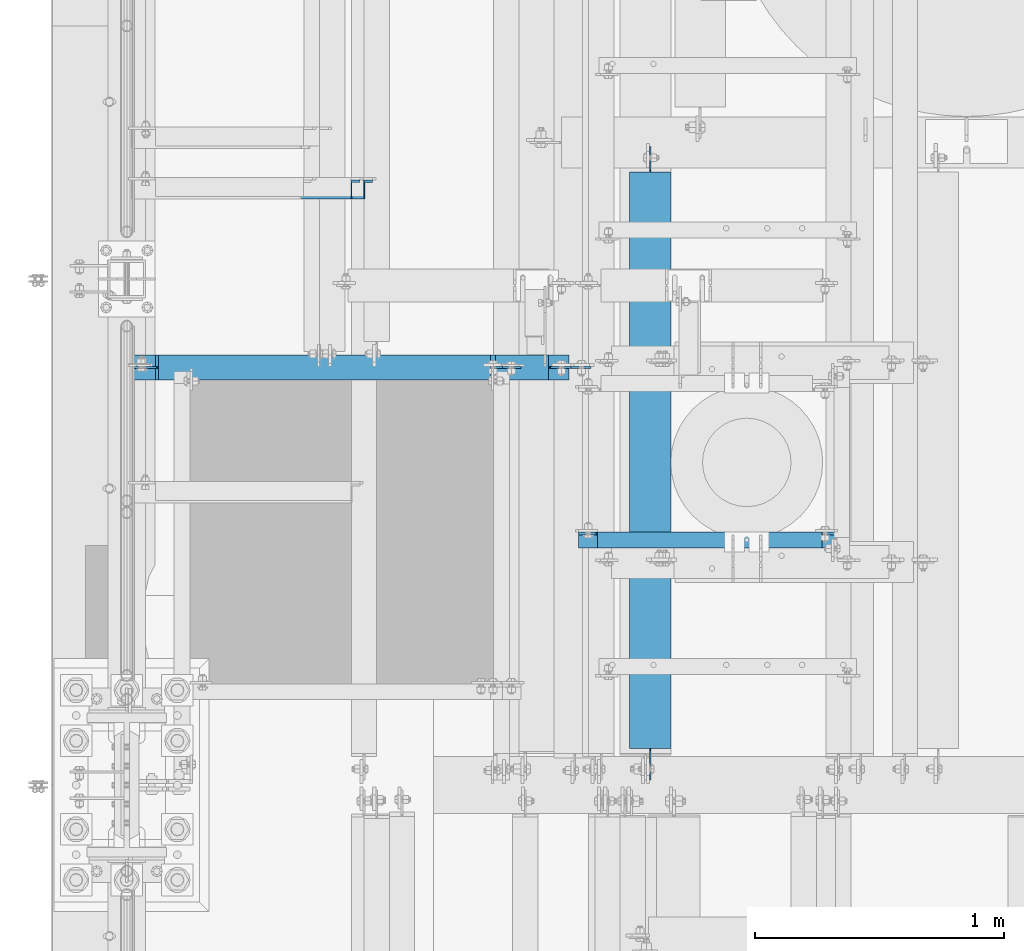
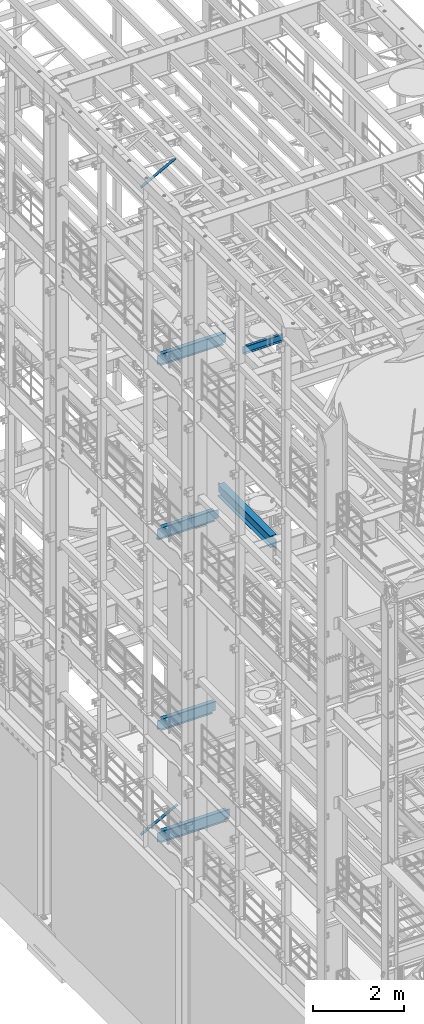
# One storey, part 1017 of 1876: 6 beams, 2 members, 8 elements without a shape of their own.
"""IFC2X3 building model written with IfcOpenShell, lengths in millimetres."""

from ifc_helpers import new_model, si_unit, frame, origin_with_axes, place, context, subcontext, project, spatial, faceted_brep, material, type_object, element, aggregate, save


model = new_model("IFC2X3")

# Units and contexts
model_context = context("Model", 3, precision=1e-05, world=origin_with_axes())
body_context = subcontext(model_context, "Body", "Model", "MODEL_VIEW")
ifc_project = project(units=[si_unit("LENGTHUNIT", "METRE", prefix="MILLI"), si_unit("AREAUNIT", "SQUARE_METRE"), si_unit("VOLUMEUNIT", "CUBIC_METRE"), si_unit("MASSUNIT", "GRAM", prefix="KILO"), si_unit("TIMEUNIT", "SECOND"), si_unit("PLANEANGLEUNIT", "RADIAN"), si_unit("SOLIDANGLEUNIT", "STERADIAN"), si_unit("THERMODYNAMICTEMPERATUREUNIT", "DEGREE_CELSIUS"), si_unit("LUMINOUSINTENSITYUNIT", "LUMEN")], contexts=[model_context])

# Site, building, storey
site_placement = place(None, origin_with_axes())
site = spatial("IfcSite", under=ifc_project, at=site_placement, CompositionType="ELEMENT")
building_placement = place(site_placement, origin_with_axes())
building = spatial("IfcBuilding", under=site, at=building_placement, Name="Undefined", CompositionType="ELEMENT")
storey_placement = place(building_placement, origin_with_axes())
storey = spatial("IfcBuildingStorey", under=building, at=storey_placement, Name="Undefined", CompositionType="ELEMENT", Elevation=0.0)

# Assembly, member
assembly_1_placement = place(storey_placement, origin_with_axes())
assembly_1 = element("IfcElementAssembly", 1, at=assembly_1_placement, inside=storey, AssemblyPlace="NOTDEFINED", PredefinedType="RIGID_FRAME")
ifc_material_1 = material(Name="STEEL/A36")
member_type = type_object("IfcMemberType", Name="L3X3X3/8", PredefinedType="NOTDEFINED")
member_1_placement = place(assembly_1_placement, frame((17.6081923269563, 3914.775, 4576.47197854001), z_axis=(0.0, -1.0, 0.0), x_axis=(0.885896503105539, 0.0, 0.463882944055263)))
member_1 = element("IfcMember", 2, at=member_1_placement, type_object=member_type, material=ifc_material_1, ObjectType="L3X3X3/8", context=body_context, shape_type="Brep", body=[
    faceted_brep([(22.4738417769599, 38.1000000000004, -38.0999999999999), (22.4738417769599, 38.1000000000004, 38.0999999999999), (1074.30197854536, 38.1000000002496, 38.0999999999999), (1074.30197854536, 38.1000000002496, -38.0999999999999), (22.4738417769613, 28.5749999999998, 38.0999999999999), (1074.30197854535, 28.5750000002463, 38.0999999999999), (22.4738417769613, 28.5749999999998, -28.5749999999998), (1074.30197854535, 28.5750000002463, -28.5749999999998), (22.4738417769699, -38.100000000004, -28.5749999999998), (1074.30197854533, -38.099999999773, -28.5749999999998), (22.4738417769699, -38.100000000004, -38.0999999999999), (1074.30197854533, -38.099999999773, -38.0999999999999)], [[[0, 1, 2, 3]], [[1, 4, 5, 2]], [[4, 6, 7, 5]], [[6, 8, 9, 7]], [[8, 10, 11, 9]], [[10, 0, 3, 11]], [[5, 7, 9, 11, 3, 2]], [[10, 8, 6, 4, 1, 0]]]),
])
aggregate(assembly_1, [member_1])

assembly_2_placement = place(storey_placement, origin_with_axes())
assembly_2 = element("IfcElementAssembly", 3, at=assembly_2_placement, inside=storey, AssemblyPlace="NOTDEFINED", PredefinedType="RIGID_FRAME")
member_2_placement = place(assembly_2_placement, frame((18.2754879686868, 3914.775, 22001.0692535961), z_axis=(0.0, -1.0, 0.0), x_axis=(0.877448093107104, 0.0, 0.479671600058526)))
member_2 = element("IfcMember", 4, at=member_2_placement, type_object=member_type, material=ifc_material_1, ObjectType="L3X3X3/8", context=body_context, shape_type="Brep", body=[
    faceted_brep([(22.6152978728696, 38.0999999999985, -38.0999999999999), (22.6152978728696, 38.0999999999985, 38.0999999999999), (1025.78606203808, 38.1000000013628, 38.0999999999999), (1025.78606203808, 38.1000000013628, -38.0999999999999), (22.6152978728605, 28.5750000000044, 38.0999999999999), (1025.78606203807, 28.5750000013722, 38.0999999999999), (22.6152978728605, 28.5750000000044, -28.5749999999998), (1025.78606203807, 28.5750000013722, -28.5749999999998), (22.6152978728023, -38.0999999999367, -28.5749999999998), (1025.78606203801, -38.0999999985652, -28.5749999999998), (22.6152978728023, -38.0999999999367, -38.0999999999999), (1025.78606203801, -38.0999999985652, -38.0999999999999)], [[[0, 1, 2, 3]], [[1, 4, 5, 2]], [[4, 6, 7, 5]], [[6, 8, 9, 7]], [[8, 10, 11, 9]], [[10, 0, 3, 11]], [[5, 7, 9, 11, 3, 2]], [[10, 8, 6, 4, 1, 0]]]),
])
aggregate(assembly_2, [member_2])

# Assembly, beam
assembly_3_placement = place(storey_placement, origin_with_axes())
assembly_3 = element("IfcElementAssembly", 5, at=assembly_3_placement, inside=storey, Name="BEAM", AssemblyPlace="NOTDEFINED", PredefinedType="RIGID_FRAME")
ifc_material_2 = material(Name="STEEL/A992")
beam_type_1 = type_object("IfcBeamType", Name="W12X16", PredefinedType="NOTDEFINED")
beam_1_placement = place(assembly_3_placement, frame((3.18323145620525e-12, 3200.4, 17830.8), z_axis=(0.0, 0.0, 1.0), x_axis=(1.0, 0.0, 0.0)))
beam_1 = element("IfcBeam", 6, at=beam_1_placement, type_object=beam_type_1, material=ifc_material_2, Name="BEAM", ObjectType="W12X16", context=body_context, shape_type="Brep", body=[
    faceted_brep([(19.84375, -3.17499999999995, -126.999999999996), (19.84375, 3.17499999999995, -126.999999999996), (96.0437501907345, 3.17500002364682, -126.999999999996), (96.0437501907345, -3.17499999999995, -126.999999999996), (100.90382970878, 3.17500002380461, -127.966729922584), (100.90382970878, -3.17499999999995, -127.966729922584), (105.024006176934, 3.17500002425209, -130.719743823061), (105.024006176934, -3.17499999999995, -130.719743823061), (107.777020077412, 3.17500002492102, -134.839920291215), (107.777020077412, -3.17499999999995, -134.839920291215), (108.74375, -3.17499999999995, -139.699999809261), (108.74375, 3.17500002570978, -139.699999809261), (108.74375, 3.17500009516311, -146.049999999999), (108.74375, 50.8, -146.049999999999), (108.74375, 50.8, -152.400000000001), (108.74375, -50.8, -152.400000000001), (108.74375, -50.8, -146.049999999999), (108.74375, -3.17499999999995, -146.049999999999), (1693.8625, 50.8000000000002, 146.049999999999), (1693.8625, 3.17500000000018, 146.049999999999), (126.20625, 3.17499999999995, 146.049999999999), (126.20625, 50.8, 146.049999999999), (113.506250190735, -3.17499999999995, 107.950000000004), (113.506250190735, 3.17499998606149, 107.950000000004), (19.84375, 3.17499999999995, 107.950000000004), (19.84375, -3.17499999999995, 107.950000000004), (118.366329708781, -3.17499999999995, 108.916729922592), (118.366329708781, 3.17499998590552, 108.916729922592), (122.486506176934, -3.17499999999995, 111.669743823069), (122.486506176934, 3.17499998546009, 111.669743823069), (125.239520077413, -3.17499999999995, 115.789920291223), (125.239520077413, 3.17499998479298, 115.789920291223), (126.20625, -3.17499999999995, 120.64999980927), (126.20625, 3.17499998400558, 120.64999980927), (1693.8625, -50.8000000000002, 152.400000000001), (1693.8625, 50.8000000000002, 152.400000000001), (126.20625, 50.8, 152.400000000001), (126.20625, -50.8, 152.400000000001), (1693.8625, -50.8000000000002, 146.049999999999), (126.20625, -50.8, 146.049999999999), (1693.8625, -3.17500000000018, 146.049999999999), (126.20625, -3.17499999999995, 146.049999999999), (1693.8625, -3.17500000000018, 139.699999809265), (1693.8625, 3.17500000000018, 139.699999809265), (1694.82922992258, -3.17500000000018, 134.839920291219), (1694.82922992258, 3.17500000000018, 134.839920291219), (1697.58224382306, -3.17500000000018, 130.719743823065), (1697.58224382306, 3.17500000000018, 130.719743823065), (1701.70242029122, -3.17500000000018, 127.966729922588), (1701.70242029122, 3.17500000000018, 127.966729922588), (1706.56249980926, -3.17500000000018, 127.0), (1706.56249980926, 3.17500000000018, 127.0), (1782.7625, -3.17500000000018, 127.0), (1782.7625, 3.17500000000018, 127.0), (1782.7625, -3.17500000000018, -127.0), (1782.7625, 3.17500000000018, -127.0), (1706.56249980926, -3.17500000000018, -127.0), (1706.56249980926, 3.17500000000018, -127.0), (1701.70242029122, -3.17500000000018, -127.966729922588), (1701.70242029122, 3.17500000000018, -127.966729922588), (1697.58224382306, -3.17500000000018, -130.719743823065), (1697.58224382306, 3.17500000000018, -130.719743823065), (1694.82922992258, -3.17500000000018, -134.839920291219), (1694.82922992258, 3.17500000000018, -134.839920291219), (1693.8625, -3.17500000000018, -139.699999809265), (1693.8625, 3.17500000000018, -139.699999809265), (1693.8625, -3.17500000000018, -146.049999999999), (1693.8625, -50.8000000000002, -146.049999999999), (1693.8625, -50.8000000000002, -152.400000000001), (1693.8625, 50.8000000000002, -152.400000000001), (1693.8625, 50.8000000000002, -146.049999999999), (1693.8625, 3.17500000000018, -146.049999999999)], [[[0, 1, 2, 3]], [[3, 2, 4, 5]], [[5, 4, 6, 7]], [[7, 6, 8, 9]], [[10, 11, 12, 13, 14, 15, 16, 17]], [[9, 8, 11, 10]], [[18, 19, 20, 21]], [[22, 23, 24, 25]], [[26, 27, 23, 22]], [[28, 29, 27, 26]], [[30, 31, 29, 28]], [[32, 33, 31, 30]], [[34, 35, 36, 37]], [[38, 34, 37, 39]], [[40, 38, 39, 41]], [[37, 36, 21, 20, 33, 32, 41, 39]], [[35, 18, 21, 36]], [[34, 38, 40, 42, 43, 19, 18, 35]], [[44, 45, 43, 42]], [[46, 47, 45, 44]], [[48, 49, 47, 46]], [[50, 51, 49, 48]], [[52, 53, 51, 50]], [[53, 52, 54, 55]], [[54, 56, 57, 55]], [[58, 59, 57, 56]], [[60, 61, 59, 58]], [[62, 63, 61, 60]], [[64, 65, 63, 62]], [[66, 67, 68, 69, 70, 71, 65, 64]], [[67, 66, 17, 16]], [[68, 67, 16, 15]], [[69, 68, 15, 14]], [[70, 69, 14, 13]], [[71, 70, 13, 12]], [[6, 4, 2, 1, 24, 23, 27, 29, 31, 33, 20, 19, 43, 45, 47, 49, 51, 53, 55, 57, 59, 61, 63, 65, 71, 12, 11, 8]], [[25, 24, 1, 0]], [[66, 64, 62, 60, 58, 56, 54, 52, 50, 48, 46, 44, 42, 40, 41, 32, 30, 28, 26, 22, 25, 0, 3, 5, 7, 9, 10, 17]]]),
])
aggregate(assembly_3, [beam_1])

assembly_4_placement = place(storey_placement, origin_with_axes())
assembly_4 = element("IfcElementAssembly", 7, at=assembly_4_placement, inside=storey, Name="BEAM", AssemblyPlace="NOTDEFINED", PredefinedType="RIGID_FRAME")
beam_2_placement = place(assembly_4_placement, frame((3.41060513164848e-12, 3200.4, 13157.2), z_axis=(0.0, 0.0, 1.0), x_axis=(1.0, 0.0, 0.0)))
beam_2 = element("IfcBeam", 8, at=beam_2_placement, type_object=beam_type_1, material=ifc_material_2, Name="BEAM", ObjectType="W12X16", context=body_context, shape_type="Brep", body=[
    faceted_brep([(115.093750190735, -3.17500000000018, 114.299999999999), (115.093750190735, 3.17500000000018, 114.299999999999), (19.84375, 3.17500000000018, 114.299999999999), (19.84375, -3.17500000000018, 114.299999999999), (119.95382970878, -3.17500000000018, 115.266729922587), (119.95382970878, 3.17500000000018, 115.266729922587), (124.074006176934, -3.17500000000018, 118.019743823065), (124.074006176934, 3.17500000000018, 118.019743823065), (126.827020077412, -3.17500000000018, 122.139920291219), (126.827020077412, 3.17500000000018, 122.139920291219), (127.79375, -3.17500000000018, 126.999999809264), (127.79375, 3.17500000000018, 126.999999809264), (127.79375, -50.8000000000002, 152.4), (127.79375, 50.8000000000002, 152.4), (127.79375, 50.8000000000002, 146.05), (127.79375, 3.17500000000018, 146.05), (127.79375, -3.17500000000018, 146.05), (127.79375, -50.8000000000002, 146.05), (19.8437499999963, -3.17500000000018, -146.049999999999), (19.8437499999963, -50.8000000000002, -146.049999999999), (1480.34375, -50.8000000000002, -146.049999999999), (1480.34375, -3.17500000000018, -146.049999999999), (19.8437499999963, -50.8000000000002, -152.4), (1480.34375, -50.8000000000002, -152.4), (19.8437499999963, 50.8000000000002, -152.4), (1480.34375, 50.8000000000002, -152.4), (19.8437499999963, 50.8000000000002, -146.049999999999), (1480.34375, 50.8000000000002, -146.049999999999), (19.8437499999963, 3.17500000000018, -146.049999999999), (1480.34375, 3.17500000000018, -146.049999999999), (1480.34375, 3.17500000000018, -139.699999809267), (1480.34375, -3.17500000000018, -139.699999809267), (1481.31047992258, 3.17500000000018, -134.839920291221), (1481.31047992258, -3.17500000000018, -134.839920291221), (1484.06349382306, 3.17500000000018, -130.719743823067), (1484.06349382306, -3.17500000000018, -130.719743823067), (1488.18367029122, 3.17500000000018, -127.966729922589), (1488.18367029122, -3.17500000000018, -127.966729922589), (1493.04374980926, 3.17500000000018, -127.000000000002), (1493.04374980926, -3.17500000000018, -127.000000000002), (1581.94375, -3.17500000000018, -127.000000000002), (1581.94375, 3.17500000000018, -127.000000000002), (1581.94375, 3.17500000000018, 107.949999999999), (1581.94375, -3.17500000000018, 107.949999999999), (1467.64374980926, 3.17500000000018, 107.949999999999), (1467.64374980926, -3.17500000000018, 107.949999999999), (1462.78367029122, 3.17500000000018, 108.916729922586), (1462.78367029122, -3.17500000000018, 108.916729922586), (1458.66349382306, 3.17500000000018, 111.669743823064), (1458.66349382306, -3.17500000000018, 111.669743823064), (1455.91047992258, 3.17500000000018, 115.789920291218), (1455.91047992258, -3.17500000000018, 115.789920291218), (1454.94375, 3.17500000000018, 120.649999809264), (1454.94375, -3.17500000000018, 120.649999809264), (1454.94375, -50.8000000000002, 152.4), (1454.94375, -50.8000000000002, 146.049999999999), (1454.94375, -3.17500000000018, 146.049999999999), (1454.94375, 3.17500000000018, 146.049999999999), (1454.94375, 50.8000000000002, 146.049999999999), (1454.94375, 50.8000000000002, 152.4)], [[[0, 1, 2, 3]], [[4, 5, 1, 0]], [[6, 7, 5, 4]], [[8, 9, 7, 6]], [[10, 11, 9, 8]], [[12, 13, 14, 15, 11, 10, 16, 17]], [[18, 19, 20, 21]], [[19, 22, 23, 20]], [[22, 24, 25, 23]], [[24, 26, 27, 25]], [[26, 28, 29, 27]], [[21, 20, 23, 25, 27, 29, 30, 31]], [[31, 30, 32, 33]], [[33, 32, 34, 35]], [[35, 34, 36, 37]], [[37, 36, 38, 39]], [[40, 39, 38, 41]], [[42, 43, 40, 41]], [[43, 42, 44, 45]], [[45, 44, 46, 47]], [[47, 46, 48, 49]], [[49, 48, 50, 51]], [[51, 50, 52, 53]], [[54, 55, 56, 53, 52, 57, 58, 59]], [[55, 54, 12, 17]], [[56, 55, 17, 16]], [[8, 6, 4, 0, 3, 18, 21, 31, 33, 35, 37, 39, 40, 43, 45, 47, 49, 51, 53, 56, 16, 10]], [[28, 26, 24, 22, 19, 18, 3, 2]], [[57, 52, 50, 48, 46, 44, 42, 41, 38, 36, 34, 32, 30, 29, 28, 2, 1, 5, 7, 9, 11, 15]], [[58, 57, 15, 14]], [[59, 58, 14, 13]], [[54, 59, 13, 12]]]),
])
aggregate(assembly_4, [beam_2])

assembly_5_placement = place(storey_placement, origin_with_axes())
assembly_5 = element("IfcElementAssembly", 9, at=assembly_5_placement, inside=storey, Name="BEAM", AssemblyPlace="NOTDEFINED", PredefinedType="RIGID_FRAME")
beam_3_placement = place(assembly_5_placement, frame((-5.6843418860808e-14, 3200.4, 8001.0), z_axis=(0.0, 0.0, 1.0), x_axis=(1.0, 0.0, 0.0)))
beam_3 = element("IfcBeam", 10, at=beam_3_placement, type_object=beam_type_1, material=ifc_material_2, Name="BEAM", ObjectType="W12X16", context=body_context, shape_type="Brep", body=[
    faceted_brep([(19.84375, -3.17499999999995, -126.999999999996), (19.84375, 3.17499999999995, -126.999999999996), (102.393750190735, 3.17500000000018, -127.000000000001), (102.393750190735, -3.17500000000018, -127.000000000001), (107.25382970878, 3.17500000000018, -127.966729922588), (107.25382970878, -3.17500000000018, -127.966729922588), (111.374006176934, 3.17500000000018, -130.719743823067), (111.374006176934, -3.17500000000018, -130.719743823067), (114.127020077412, 3.17500000000018, -134.839920291221), (114.127020077412, -3.17500000000018, -134.839920291221), (115.09375, -3.17500000000018, -139.699999809266), (115.09375, 3.17500000000018, -139.699999809266), (115.09375, 3.17500000000018, -146.05), (115.09375, 50.8000000000002, -146.05), (115.09375, 50.8000000000002, -152.4), (115.09375, -50.8000000000002, -152.4), (115.09375, -50.8000000000002, -146.05), (115.09375, -3.17500000000018, -146.05), (1460.50012207031, 50.8000000000002, 146.05), (1460.50012207031, 3.17500000000018, 146.05), (127.79375, 3.17500000000018, 146.05), (127.79375, 50.8000000000002, 146.05), (115.093750190735, -3.17500000000018, 114.299999999999), (115.093750190735, 3.17500000000018, 114.299999999999), (19.84375, 3.17500000000018, 114.299999999999), (19.84375, -3.17500000000018, 114.299999999999), (119.95382970878, -3.17500000000018, 115.266729922587), (119.95382970878, 3.17500000000018, 115.266729922587), (124.074006176934, -3.17500000000018, 118.019743823065), (124.074006176934, 3.17500000000018, 118.019743823065), (126.827020077412, -3.17500000000018, 122.139920291219), (126.827020077412, 3.17500000000018, 122.139920291219), (127.79375, -3.17500000000018, 126.999999809264), (127.79375, 3.17500000000018, 126.999999809264), (1460.50012207031, -50.8000000000002, 152.4), (1460.50012207031, 50.8000000000002, 152.4), (127.79375, 50.8000000000002, 152.4), (127.79375, -50.8000000000002, 152.4), (1460.50012207031, -50.8000000000002, 146.05), (127.79375, -50.8000000000002, 146.05), (1460.50012207031, -3.17500000000018, 146.05), (127.79375, -3.17500000000018, 146.05), (1460.50012207031, -3.17500000000018, 139.699999809264), (1460.50012207031, 3.17500000000018, 139.699999809264), (1461.4668519929, -3.17500000000018, 134.839920291219), (1461.4668519929, 3.17500000000018, 134.839920291219), (1464.21986589337, -3.17500000000018, 130.719743823065), (1464.21986589337, 3.17500000000018, 130.719743823065), (1468.34004236153, -3.17500000000018, 127.966729922587), (1468.34004236153, 3.17500000000018, 127.966729922587), (1473.20012187957, -3.17500000000018, 126.999999999999), (1473.20012187957, 3.17500000000018, 126.999999999999), (1508.12512207031, -3.17500000000018, 126.999999999999), (1508.12512207031, 3.17500000000018, 126.999999999999), (1508.12512207031, -3.17500000000018, -127.000000000001), (1508.12512207031, 3.17500000000018, -127.000000000001), (1431.92512187957, -3.17500000000018, -127.000000000001), (1431.92512187957, 3.17500000000018, -127.000000000001), (1427.06504236153, -3.17500000000018, -127.966729922588), (1427.06504236153, 3.17500000000018, -127.966729922588), (1422.94486589337, -3.17500000000018, -130.719743823067), (1422.94486589337, 3.17500000000018, -130.719743823067), (1420.1918519929, -3.17500000000018, -134.839920291221), (1420.1918519929, 3.17500000000018, -134.839920291221), (1419.22512207031, -3.17500000000018, -139.699999809266), (1419.22512207031, 3.17500000000018, -139.699999809266), (1419.22512207031, -3.17500000000018, -146.05), (1419.22512207031, -50.8000000000002, -146.05), (1419.22512207031, -50.8000000000002, -152.4), (1419.22512207031, 50.8000000000002, -152.4), (1419.22512207031, 50.8000000000002, -146.05), (1419.22512207031, 3.17500000000018, -146.05)], [[[0, 1, 2, 3]], [[3, 2, 4, 5]], [[5, 4, 6, 7]], [[7, 6, 8, 9]], [[10, 11, 12, 13, 14, 15, 16, 17]], [[9, 8, 11, 10]], [[18, 19, 20, 21]], [[22, 23, 24, 25]], [[26, 27, 23, 22]], [[28, 29, 27, 26]], [[30, 31, 29, 28]], [[32, 33, 31, 30]], [[34, 35, 36, 37]], [[38, 34, 37, 39]], [[40, 38, 39, 41]], [[37, 36, 21, 20, 33, 32, 41, 39]], [[35, 18, 21, 36]], [[34, 38, 40, 42, 43, 19, 18, 35]], [[44, 45, 43, 42]], [[46, 47, 45, 44]], [[48, 49, 47, 46]], [[50, 51, 49, 48]], [[52, 53, 51, 50]], [[53, 52, 54, 55]], [[54, 56, 57, 55]], [[58, 59, 57, 56]], [[60, 61, 59, 58]], [[62, 63, 61, 60]], [[64, 65, 63, 62]], [[66, 67, 68, 69, 70, 71, 65, 64]], [[67, 66, 17, 16]], [[68, 67, 16, 15]], [[69, 68, 15, 14]], [[70, 69, 14, 13]], [[71, 70, 13, 12]], [[6, 4, 2, 1, 24, 23, 27, 29, 31, 33, 20, 19, 43, 45, 47, 49, 51, 53, 55, 57, 59, 61, 63, 65, 71, 12, 11, 8]], [[25, 24, 1, 0]], [[66, 64, 62, 60, 58, 56, 54, 52, 50, 48, 46, 44, 42, 40, 41, 32, 30, 28, 26, 22, 25, 0, 3, 5, 7, 9, 10, 17]]]),
])
aggregate(assembly_5, [beam_3])

assembly_6_placement = place(storey_placement, origin_with_axes())
assembly_6 = element("IfcElementAssembly", 11, at=assembly_6_placement, inside=storey, Name="BEAM", AssemblyPlace="NOTDEFINED", PredefinedType="RIGID_FRAME")
beam_4_placement = place(assembly_6_placement, frame((-4.54747350886464e-13, 3200.4, 4978.4), z_axis=(0.0, 0.0, 1.0), x_axis=(1.0, 0.0, 0.0)))
beam_4 = element("IfcBeam", 12, at=beam_4_placement, type_object=beam_type_1, material=ifc_material_2, Name="BEAM", ObjectType="W12X16", context=body_context, shape_type="Brep", body=[
    faceted_brep([(19.84375, -3.17499999999995, -126.999999999996), (19.84375, 3.17499999999995, -126.999999999996), (102.393750190735, 3.17500000000018, -127.000000000001), (102.393750190735, -3.17500000000018, -127.000000000001), (107.25382970878, 3.17500000000018, -127.966729922588), (107.25382970878, -3.17500000000018, -127.966729922588), (111.374006176934, 3.17500000000018, -130.719743823067), (111.374006176934, -3.17500000000018, -130.719743823067), (114.127020077412, 3.17500000000018, -134.839920291221), (114.127020077412, -3.17500000000018, -134.839920291221), (115.09375, -3.17500000000018, -139.699999809266), (115.09375, 3.17500000000018, -139.699999809266), (115.09375, 3.17500000000018, -146.05), (115.09375, 50.8000000000002, -146.05), (115.09375, 50.8000000000002, -152.4), (115.09375, -50.8000000000002, -152.4), (115.09375, -50.8000000000002, -146.05), (115.09375, -3.17500000000018, -146.05), (1774.825, 50.8000000000002, 146.05), (1774.825, 3.17500000000018, 146.05), (127.79375, 3.17500000000018, 146.05), (127.79375, 50.8000000000002, 146.05), (115.093750190735, -3.17500000000018, 114.299999999999), (115.093750190735, 3.17500000000018, 114.299999999999), (19.84375, 3.17500000000018, 114.299999999999), (19.84375, -3.17500000000018, 114.299999999999), (119.95382970878, -3.17500000000018, 115.266729922587), (119.95382970878, 3.17500000000018, 115.266729922587), (124.074006176934, -3.17500000000018, 118.019743823065), (124.074006176934, 3.17500000000018, 118.019743823065), (126.827020077412, -3.17500000000018, 122.139920291219), (126.827020077412, 3.17500000000018, 122.139920291219), (127.79375, -3.17500000000018, 126.999999809264), (127.79375, 3.17500000000018, 126.999999809264), (1774.825, -50.8000000000002, 152.4), (1774.825, 50.8000000000002, 152.4), (127.79375, 50.8000000000002, 152.4), (127.79375, -50.8000000000002, 152.4), (1774.825, -50.8000000000002, 146.05), (127.79375, -50.8000000000002, 146.05), (1774.825, -3.17500000000018, 146.05), (127.79375, -3.17500000000018, 146.05), (1774.825, -3.17500000000018, 139.699999809264), (1774.825, 3.17500000000018, 139.699999809264), (1775.79172992259, -3.17500000000018, 134.839920291219), (1775.79172992259, 3.17500000000018, 134.839920291219), (1778.54474382307, -3.17500000000018, 130.719743823065), (1778.54474382307, 3.17500000000018, 130.719743823065), (1782.66492029122, -3.17500000000018, 127.966729922587), (1782.66492029122, 3.17500000000018, 127.966729922587), (1787.52499980926, -3.17500000000018, 126.999999999999), (1787.52499980926, 3.17500000000018, 126.999999999999), (1863.725, -3.17500000000018, 126.999999999999), (1863.725, 3.17500000000018, 126.999999999999), (1863.725, -3.17500000000018, -127.000000000001), (1863.725, 3.17500000000018, -127.000000000001), (1736.72499980926, -3.17500000000018, -127.000000000001), (1736.72499980926, 3.17500000000018, -127.000000000001), (1731.86492029122, -3.17500000000018, -127.966729922588), (1731.86492029122, 3.17500000000018, -127.966729922588), (1727.74474382307, -3.17500000000018, -130.719743823067), (1727.74474382307, 3.17500000000018, -130.719743823067), (1724.99172992259, -3.17500000000018, -134.839920291221), (1724.99172992259, 3.17500000000018, -134.839920291221), (1724.025, -3.17500000000018, -139.699999809266), (1724.025, 3.17500000000018, -139.699999809266), (1724.025, -3.17500000000018, -146.05), (1724.025, -50.8000000000002, -146.05), (1724.025, -50.8000000000002, -152.4), (1724.025, 50.8000000000002, -152.4), (1724.025, 50.8000000000002, -146.05), (1724.025, 3.17500000000018, -146.05)], [[[0, 1, 2, 3]], [[3, 2, 4, 5]], [[5, 4, 6, 7]], [[7, 6, 8, 9]], [[10, 11, 12, 13, 14, 15, 16, 17]], [[9, 8, 11, 10]], [[18, 19, 20, 21]], [[22, 23, 24, 25]], [[26, 27, 23, 22]], [[28, 29, 27, 26]], [[30, 31, 29, 28]], [[32, 33, 31, 30]], [[34, 35, 36, 37]], [[38, 34, 37, 39]], [[40, 38, 39, 41]], [[37, 36, 21, 20, 33, 32, 41, 39]], [[35, 18, 21, 36]], [[34, 38, 40, 42, 43, 19, 18, 35]], [[44, 45, 43, 42]], [[46, 47, 45, 44]], [[48, 49, 47, 46]], [[50, 51, 49, 48]], [[52, 53, 51, 50]], [[53, 52, 54, 55]], [[54, 56, 57, 55]], [[58, 59, 57, 56]], [[60, 61, 59, 58]], [[62, 63, 61, 60]], [[64, 65, 63, 62]], [[66, 67, 68, 69, 70, 71, 65, 64]], [[67, 66, 17, 16]], [[68, 67, 16, 15]], [[69, 68, 15, 14]], [[70, 69, 14, 13]], [[71, 70, 13, 12]], [[6, 4, 2, 1, 24, 23, 27, 29, 31, 33, 20, 19, 43, 45, 47, 49, 51, 53, 55, 57, 59, 61, 63, 65, 71, 12, 11, 8]], [[25, 24, 1, 0]], [[66, 64, 62, 60, 58, 56, 54, 52, 50, 48, 46, 44, 42, 40, 41, 32, 30, 28, 26, 22, 25, 0, 3, 5, 7, 9, 10, 17]]]),
])
aggregate(assembly_6, [beam_4])

assembly_7_placement = place(storey_placement, origin_with_axes())
assembly_7 = element("IfcElementAssembly", 13, at=assembly_7_placement, inside=storey, Name="BEAM", AssemblyPlace="NOTDEFINED", PredefinedType="RIGID_FRAME")
beam_type_2 = type_object("IfcBeamType", Name="C8X18.75", PredefinedType="NOTDEFINED")
beam_5_placement = place(assembly_7_placement, frame((1790.7, 2508.25, 17881.6), z_axis=(0.0, 0.0, 1.0), x_axis=(1.0, 0.0, 0.0)))
beam_5 = element("IfcBeam", 14, at=beam_5_placement, type_object=beam_type_2, material=ifc_material_1, Name="BEAM", ObjectType="C8X18.75", context=body_context, shape_type="Brep", body=[
    faceted_brep([(1000.125, -31.75, 101.599999999999), (1000.125, -31.75, 97.3645499999984), (1000.125, 19.0500000000002, 88.9012699999985), (1000.125, 31.75, 88.8999998092659), (1000.125, 31.75, 101.599999999999), (1001.09172992259, 19.0500000000002, 84.0399202912195), (1001.09172992259, 31.75, 84.0399202912195), (1003.84474382307, 19.0500000000002, 79.9197438230658), (1003.84474382307, 31.75, 79.9197438230658), (1007.96492029122, 19.0500000000002, 77.1667299225883), (1007.96492029122, 31.75, 77.1667299225883), (1012.82499980927, 19.0500000000002, 76.2000000000007), (1012.82499980927, 31.75, 76.2000000000007), (1050.925, 19.0500000000002, 76.2000000000007), (1050.925, 31.75, 76.2000000000007), (100.012500000004, -31.75, 101.599999999999), (100.012500000004, 31.75, 101.599999999999), (100.012500000004, 31.75, 88.8999998092659), (100.012500000004, 19.0500000000002, 88.9012699999985), (100.012500000004, -31.75, 97.3645499999984), (99.0457700774164, 31.75, 84.0399202912195), (99.0457700774164, 19.0500000000002, 84.0399202912195), (96.2927561769382, 31.75, 79.9197438230658), (96.2927561769382, 19.0500000000002, 79.9197438230658), (92.1725797087845, 31.75, 77.1667299225883), (92.1725797087845, 19.0500000000002, 77.1667299225883), (87.312500190739, 31.75, 76.2000000000007), (87.312500190739, 19.0500000000002, 76.2000000000007), (23.8125000000041, 31.75, 76.2000000000007), (23.8125000000041, 19.0500000000002, 76.2000000000007), (23.8125000000041, 31.75, -101.599999999999), (23.8125000000041, -31.75, -101.599999999999), (23.8125000000041, -31.75, -97.3645499999984), (23.8125000000041, 19.0500000000002, -88.9012699999985), (1050.925, 31.75, -101.599999999999), (1050.925, -31.75, -101.599999999999), (1050.925, -31.75, -97.3645499999984), (1050.925, 19.0500000000002, -88.9012699999985)], [[[0, 1, 2, 3, 4]], [[5, 6, 3, 2]], [[7, 8, 6, 5]], [[9, 10, 8, 7]], [[11, 12, 10, 9]], [[13, 14, 12, 11]], [[15, 16, 17, 18, 19]], [[18, 17, 20, 21]], [[21, 20, 22, 23]], [[23, 22, 24, 25]], [[25, 24, 26, 27]], [[27, 26, 28, 29]], [[30, 31, 32, 33, 29, 28]], [[31, 30, 34, 35]], [[32, 31, 35, 36]], [[33, 32, 36, 37]], [[9, 7, 5, 2, 18, 21, 23, 25, 27, 29, 33, 37, 13, 11]], [[19, 18, 2, 1]], [[15, 19, 1, 0]], [[16, 15, 0, 4]], [[34, 30, 28, 26, 24, 22, 20, 17, 16, 4, 3, 6, 8, 10, 12, 14]], [[37, 36, 35, 34, 14, 13]]]),
])
aggregate(assembly_7, [beam_5])

assembly_8_placement = place(storey_placement, origin_with_axes())
assembly_8 = element("IfcElementAssembly", 15, at=assembly_8_placement, inside=storey, Name="BEAM", AssemblyPlace="NOTDEFINED", PredefinedType="RIGID_FRAME")
beam_type_3 = type_object("IfcBeamType", Name="W12X30", PredefinedType="NOTDEFINED")
beam_6_placement = place(assembly_8_placement, frame((2101.85, 1524.0, 13152.4375), z_axis=(0.0, 0.0, 1.0), x_axis=(0.0, 1.0, 0.0)))
beam_6 = element("IfcBeam", 16, at=beam_6_placement, type_object=beam_type_3, material=ifc_material_2, Name="BEAM", ObjectType="W12X30", context=body_context, shape_type="Brep", body=[
    faceted_brep([(19.8437500000002, -3.17500000000018, -131.762499999993), (19.8437500000002, 3.17500000000018, -131.762499999993), (134.143750190735, 3.17500000000018, -131.762500000001), (134.143750190735, -3.17500000000018, -131.762500000001), (139.00382970878, 3.17500000000018, -132.729229922588), (139.00382970878, -3.17500000000018, -132.729229922588), (143.124006176934, 3.17500000000018, -135.482243823066), (143.124006176934, -3.17500000000018, -135.482243823066), (145.877020077412, 3.17500000000018, -139.602420291219), (145.877020077412, -3.17500000000018, -139.602420291219), (146.84375, -3.17500000000018, -144.462499809266), (146.84375, 3.17500000000018, -144.462499809266), (146.84375, 3.17500000000018, -146.049999999999), (146.84375, 82.5500000000002, -146.049999999999), (146.84375, 82.5500000000002, -157.1625), (146.84375, -82.5500000000002, -157.1625), (146.84375, -82.5500000000002, -146.049999999999), (146.84375, -3.17500000000018, -146.049999999999), (2461.41875, 82.5500000000002, 146.049999999999), (2461.41875, 3.17500000000018, 146.049999999999), (146.84375, 3.17500000000018, 146.049999999999), (146.84375, 82.5500000000002, 146.049999999999), (134.143750190735, -3.17500000000018, 119.0625), (134.143750190735, 3.17500000000018, 119.0625), (19.8437491105051, 3.17499999999995, 119.062500000004), (19.8437491105051, -3.17499999999995, 119.062500000004), (139.00382970878, -3.17500000000018, 120.029229922588), (139.00382970878, 3.17500000000018, 120.029229922588), (143.124006176934, -3.17500000000018, 122.782243823065), (143.124006176934, 3.17500000000018, 122.782243823065), (145.877020077412, -3.17500000000018, 126.902420291219), (145.877020077412, 3.17500000000018, 126.902420291219), (146.84375, -3.17500000000018, 131.762499809265), (146.84375, 3.17500000000018, 131.762499809265), (2461.41875, -82.5500000000002, 157.1625), (2461.41875, 82.5500000000002, 157.1625), (146.84375, 82.5500000000002, 157.1625), (146.84375, -82.5500000000002, 157.1625), (2461.41875, -82.5500000000002, 146.049999999999), (146.84375, -82.5500000000002, 146.049999999999), (2461.41875, -3.17500000000018, 146.049999999999), (146.84375, -3.17500000000018, 146.049999999999), (2461.41875, -3.17500000000018, 131.762499809265), (2461.41875, 3.17500000000018, 131.762499809265), (2462.38547992259, -3.17500000000018, 126.902420291219), (2462.38547992259, 3.17500000000018, 126.902420291219), (2465.13849382307, -3.17500000000018, 122.782243823065), (2465.13849382307, 3.17500000000018, 122.782243823065), (2469.25867029122, -3.17500000000018, 120.029229922588), (2469.25867029122, 3.17500000000018, 120.029229922588), (2474.11874980927, -3.17500000000018, 119.0625), (2474.11874980927, 3.17500000000018, 119.0625), (2563.01875, -3.17500000000018, 119.0625), (2563.01875, 3.17500000000018, 119.0625), (2563.01875, -3.17500000000018, -131.762500000001), (2563.01875, 3.17500000000018, -131.762500000001), (2474.11874980927, -3.17500000000018, -131.762500000001), (2474.11874980927, 3.17500000000018, -131.762500000001), (2469.25867029122, -3.17500000000018, -132.729229922588), (2469.25867029122, 3.17500000000018, -132.729229922588), (2465.13849382307, -3.17500000000018, -135.482243823066), (2465.13849382307, 3.17500000000018, -135.482243823066), (2462.38547992259, -3.17500000000018, -139.602420291219), (2462.38547992259, 3.17500000000018, -139.602420291219), (2461.41875, -3.17500000000018, -144.462499809266), (2461.41875, 3.17500000000018, -144.462499809266), (2461.41875, -3.17500000000018, -146.049999999999), (2461.41875, -82.5500000000002, -146.049999999999), (2461.41875, -82.5500000000002, -157.1625), (2461.41875, 82.5500000000002, -157.1625), (2461.41875, 82.5500000000002, -146.049999999999), (2461.41875, 3.17500000000018, -146.049999999999)], [[[0, 1, 2, 3]], [[3, 2, 4, 5]], [[5, 4, 6, 7]], [[7, 6, 8, 9]], [[10, 11, 12, 13, 14, 15, 16, 17]], [[9, 8, 11, 10]], [[18, 19, 20, 21]], [[22, 23, 24, 25]], [[26, 27, 23, 22]], [[28, 29, 27, 26]], [[30, 31, 29, 28]], [[32, 33, 31, 30]], [[34, 35, 36, 37]], [[38, 34, 37, 39]], [[40, 38, 39, 41]], [[37, 36, 21, 20, 33, 32, 41, 39]], [[35, 18, 21, 36]], [[34, 38, 40, 42, 43, 19, 18, 35]], [[44, 45, 43, 42]], [[46, 47, 45, 44]], [[48, 49, 47, 46]], [[50, 51, 49, 48]], [[52, 53, 51, 50]], [[53, 52, 54, 55]], [[54, 56, 57, 55]], [[58, 59, 57, 56]], [[60, 61, 59, 58]], [[62, 63, 61, 60]], [[64, 65, 63, 62]], [[66, 67, 68, 69, 70, 71, 65, 64]], [[67, 66, 17, 16]], [[68, 67, 16, 15]], [[69, 68, 15, 14]], [[70, 69, 14, 13]], [[71, 70, 13, 12]], [[6, 4, 2, 1, 24, 23, 27, 29, 31, 33, 20, 19, 43, 45, 47, 49, 51, 53, 55, 57, 59, 61, 63, 65, 71, 12, 11, 8]], [[25, 24, 1, 0]], [[66, 64, 62, 60, 58, 56, 54, 52, 50, 48, 46, 44, 42, 40, 41, 32, 30, 28, 26, 22, 25, 0, 3, 5, 7, 9, 10, 17]]]),
])
aggregate(assembly_8, [beam_6])

save(model, "model.ifc")
